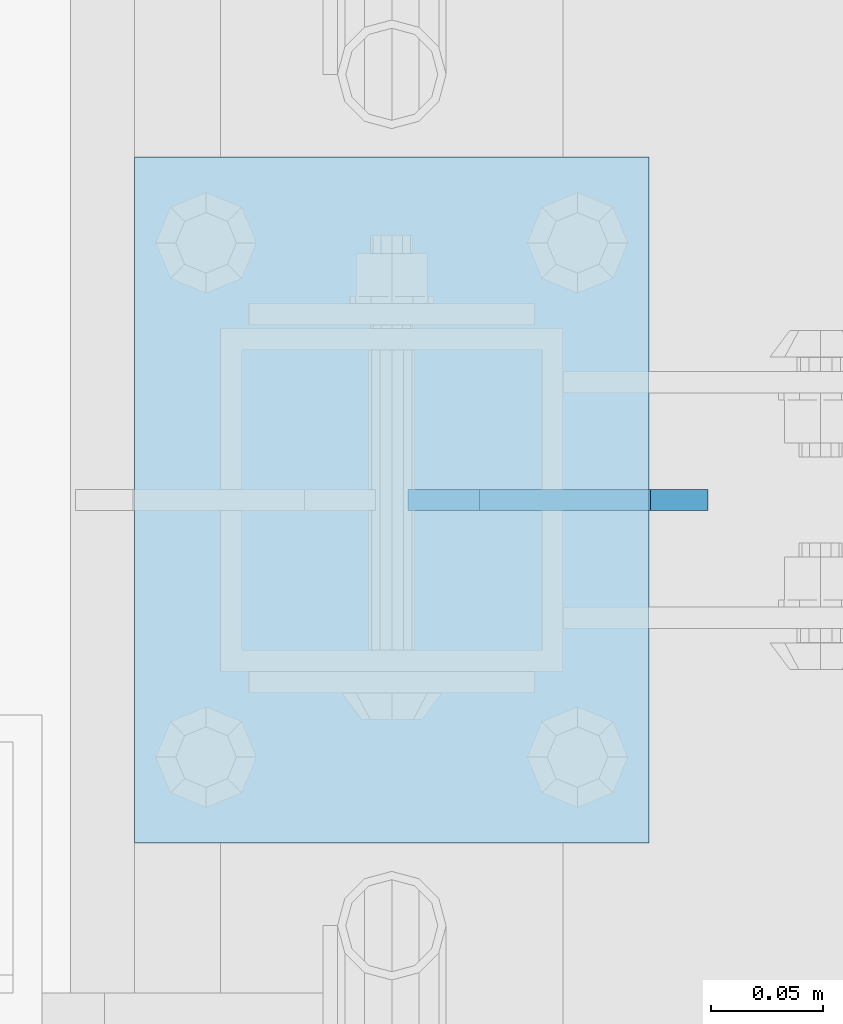
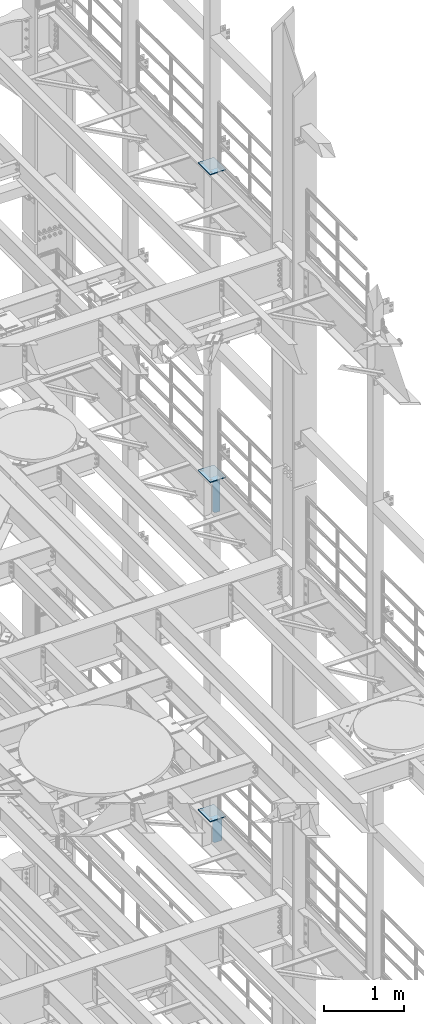
# One storey, part 1818 of 1876: 5 plates, 5 elements without a shape of their own.
"""IFC2X3 building model written with IfcOpenShell, lengths in millimetres."""

from ifc_helpers import new_model, si_unit, frame, origin_with_axes, place, context, subcontext, project, spatial, faceted_brep, material, type_object, element, aggregate, save


model = new_model("IFC2X3")

# Units and contexts
model_context = context("Model", 3, precision=1e-05, world=origin_with_axes())
body_context = subcontext(model_context, "Body", "Model", "MODEL_VIEW")
ifc_project = project(units=[si_unit("LENGTHUNIT", "METRE", prefix="MILLI"), si_unit("AREAUNIT", "SQUARE_METRE"), si_unit("VOLUMEUNIT", "CUBIC_METRE"), si_unit("MASSUNIT", "GRAM", prefix="KILO"), si_unit("TIMEUNIT", "SECOND"), si_unit("PLANEANGLEUNIT", "RADIAN"), si_unit("SOLIDANGLEUNIT", "STERADIAN"), si_unit("THERMODYNAMICTEMPERATUREUNIT", "DEGREE_CELSIUS"), si_unit("LUMINOUSINTENSITYUNIT", "LUMEN")], contexts=[model_context])

# Site, building, storey
site_placement = place(None, origin_with_axes())
site = spatial("IfcSite", under=ifc_project, at=site_placement, CompositionType="ELEMENT")
building_placement = place(site_placement, origin_with_axes())
building = spatial("IfcBuilding", under=site, at=building_placement, Name="Undefined", CompositionType="ELEMENT")
storey_placement = place(building_placement, origin_with_axes())
storey = spatial("IfcBuildingStorey", under=building, at=storey_placement, Name="Undefined", CompositionType="ELEMENT", Elevation=0.0)

# Assembly, plate
assembly_1_placement = place(storey_placement, origin_with_axes())
assembly_1 = element("IfcElementAssembly", 1, at=assembly_1_placement, inside=storey, Name="BEAM", AssemblyPlace="NOTDEFINED", PredefinedType="RIGID_FRAME")
ifc_material = material(Name="STEEL/A36")
plate_type_1 = type_object("IfcPlateType", PredefinedType="NOTDEFINED")
plate_1_placement = place(assembly_1_placement, frame((7760.49375, 9652.0, 7700.9625), z_axis=(0.0, 0.0, 1.0), x_axis=(-1.0, 0.0, 0.0)))
plate_1 = element("IfcPlate", 2, at=plate_1_placement, type_object=plate_type_1, material=ifc_material, Name="PLATE", context=body_context, shape_type="Brep", body=[
    faceted_brep([(0.0, -4.76249999999982, 0.0), (0.0, -4.76250000000073, 428.625), (0.0, 4.76250000000073, 428.625), (0.0, 4.76249999999982, 0.0), (107.950006484985, -4.76250000000073, 428.625), (107.950006484985, 4.76250000000073, 428.625), (133.350006103516, -4.76250000000073, 403.22500038147), (133.350006103516, 4.76250000000073, 403.22500038147), (133.350006103516, -4.76250000000073, 25.3999996185303), (133.350006103516, 4.76250000000073, 25.3999996185303), (107.950006484985, -4.76250000000073, 0.0), (107.950006484985, 4.76250000000073, 0.0)], [[[0, 1, 2, 3]], [[1, 4, 5, 2]], [[4, 6, 7, 5]], [[6, 8, 9, 7]], [[8, 10, 11, 9]], [[10, 0, 3, 11]], [[5, 7, 9, 11, 3, 2]], [[10, 8, 6, 4, 1, 0]]]),
])
aggregate(assembly_1, [plate_1])

assembly_2_placement = place(storey_placement, origin_with_axes())
assembly_2 = element("IfcElementAssembly", 3, at=assembly_2_placement, inside=storey, Name="BEAM", AssemblyPlace="NOTDEFINED", PredefinedType="RIGID_FRAME")
plate_type_2 = type_object("IfcPlateType", PredefinedType="NOTDEFINED")
plate_2_placement = place(assembly_2_placement, frame((7735.09375, 9652.0, 12712.7), z_axis=(0.0, 0.0, 1.0), x_axis=(-1.0, 0.0, 0.0)))
plate_2 = element("IfcPlate", 4, at=plate_2_placement, type_object=plate_type_2, material=ifc_material, Name="PLATE", context=body_context, shape_type="Brep", body=[
    faceted_brep([(0.0, -4.76249999999982, 0.0), (0.0, -4.76249999999982, 571.5), (0.0, 4.76249999999982, 571.5), (0.0, 4.76249999999982, 0.0), (76.1999969482422, -4.76249999999982, 571.5), (76.1999969482422, 4.76249999999982, 571.5), (107.949996948242, -4.76249999999982, 539.75), (107.949996948242, 4.76249999999982, 539.75), (107.949996948242, -4.76249999999982, 31.75), (107.949996948242, 4.76249999999982, 31.75), (76.1999969482422, -4.76250000000073, 0.0), (76.1999969482422, 4.76250000000073, 0.0)], [[[0, 1, 2, 3]], [[1, 4, 5, 2]], [[4, 6, 7, 5]], [[6, 8, 9, 7]], [[8, 10, 11, 9]], [[10, 0, 3, 11]], [[5, 7, 9, 11, 3, 2]], [[10, 8, 6, 4, 1, 0]]]),
])
aggregate(assembly_2, [plate_2])

assembly_3_placement = place(storey_placement, origin_with_axes())
assembly_3 = element("IfcElementAssembly", 5, at=assembly_3_placement, inside=storey, Name="BEAM", AssemblyPlace="NOTDEFINED", PredefinedType="RIGID_FRAME")
plate_type_3 = type_object("IfcPlateType", PredefinedType="NOTDEFINED")
plate_3_placement = place(assembly_3_placement, frame((7505.7, 9499.6, 17989.55), z_axis=(0.0, 1.0, 0.0), x_axis=(1.0, 0.0, 0.0)))
plate_3 = element("IfcPlate", 6, at=plate_3_placement, type_object=plate_type_3, material=ifc_material, Name="PLATE", context=body_context, shape_type="Brep", body=[
    faceted_brep([(0.0, -6.35000000000036, 0.0), (0.0, -6.35000000000036, 304.799987792969), (0.0, 6.35000000000036, 304.799987792969), (0.0, 6.35000000000036, 0.0), (228.600006103516, -6.34999999999854, 304.799987792969), (228.600006103516, 6.34999999999854, 304.799987792969), (228.600006103516, -6.34999999999854, 0.0), (228.600006103516, 6.34999999999854, 0.0)], [[[0, 1, 2, 3]], [[1, 4, 5, 2]], [[4, 6, 7, 5]], [[6, 0, 3, 7]], [[5, 7, 3, 2]], [[6, 4, 1, 0]]]),
])
aggregate(assembly_3, [plate_3])

assembly_4_placement = place(storey_placement, origin_with_axes())
assembly_4 = element("IfcElementAssembly", 7, at=assembly_4_placement, inside=storey, Name="BEAM", AssemblyPlace="NOTDEFINED", PredefinedType="RIGID_FRAME")
plate_4_placement = place(assembly_4_placement, frame((7505.7, 9499.6, 13315.95), z_axis=(0.0, 1.0, 0.0), x_axis=(1.0, 0.0, 0.0)))
plate_4 = element("IfcPlate", 8, at=plate_4_placement, type_object=plate_type_3, material=ifc_material, Name="PLATE", context=body_context, shape_type="Brep", body=[
    faceted_brep([(0.0, -6.35000000000036, 0.0), (0.0, -6.35000000000036, 304.799987792969), (0.0, 6.35000000000036, 304.799987792969), (0.0, 6.35000000000036, 0.0), (228.600006103516, -6.34999999999854, 304.799987792969), (228.600006103516, 6.34999999999854, 304.799987792969), (228.600006103516, -6.34999999999854, 0.0), (228.600006103516, 6.34999999999854, 0.0)], [[[0, 1, 2, 3]], [[1, 4, 5, 2]], [[4, 6, 7, 5]], [[6, 0, 3, 7]], [[5, 7, 3, 2]], [[6, 4, 1, 0]]]),
])
aggregate(assembly_4, [plate_4])

assembly_5_placement = place(storey_placement, origin_with_axes())
assembly_5 = element("IfcElementAssembly", 9, at=assembly_5_placement, inside=storey, Name="BEAM", AssemblyPlace="NOTDEFINED", PredefinedType="RIGID_FRAME")
plate_5_placement = place(assembly_5_placement, frame((7505.7, 9499.6, 8159.75), z_axis=(0.0, 1.0, 0.0), x_axis=(1.0, 0.0, 0.0)))
plate_5 = element("IfcPlate", 10, at=plate_5_placement, type_object=plate_type_3, material=ifc_material, Name="PLATE", context=body_context, shape_type="Brep", body=[
    faceted_brep([(0.0, -6.35000000000036, 0.0), (0.0, -6.35000000000036, 304.799987792969), (0.0, 6.35000000000036, 304.799987792969), (0.0, 6.35000000000036, 0.0), (228.600006103516, -6.34999999999854, 304.799987792969), (228.600006103516, 6.34999999999854, 304.799987792969), (228.600006103516, -6.34999999999854, 0.0), (228.600006103516, 6.34999999999854, 0.0)], [[[0, 1, 2, 3]], [[1, 4, 5, 2]], [[4, 6, 7, 5]], [[6, 0, 3, 7]], [[5, 7, 3, 2]], [[6, 4, 1, 0]]]),
])
aggregate(assembly_5, [plate_5])

save(model, "model.ifc")
